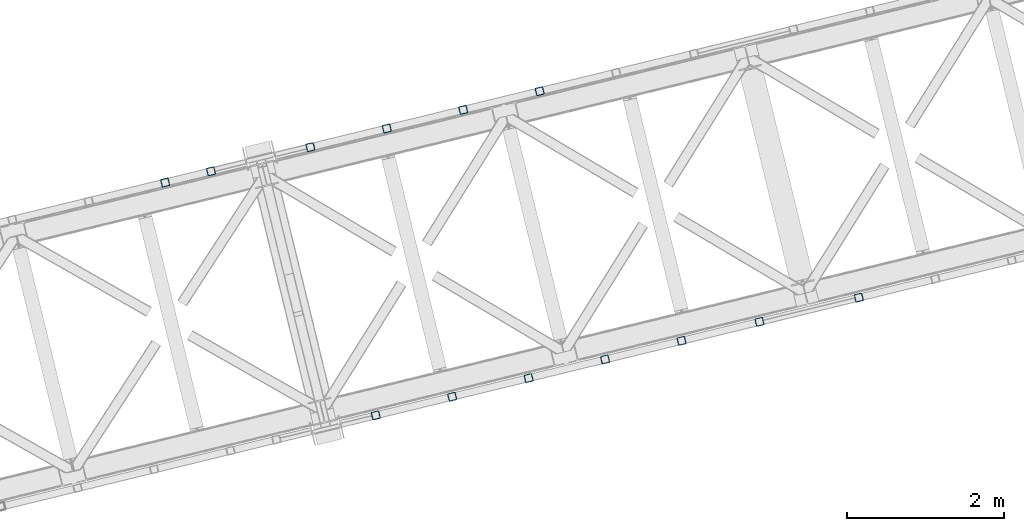
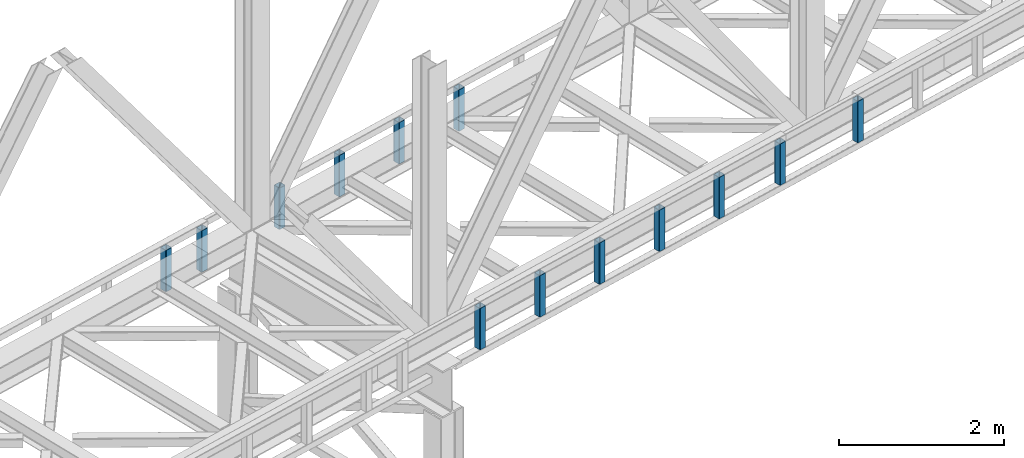
# One storey, part 9 of 92: 13 columns.
"""IFC4 building model written with IfcOpenShell, lengths in millimetres."""

import ifcopenshell
import ifcopenshell.guid

model = None  # the IFC model being written
_history = None  # IfcOwnerHistory: only IFC2X3 demands one
_inside = {}  # id of a spatial element -> (the spatial element, [elements in it])
_under = {}  # id of a project, library or spatial element -> (it, [spatial elements below it])
_declared = {}  # id of a project -> (the project, [libraries it declares])
_typed = {}  # id of a type object -> (the type object, [elements of that type])
_made_of = {}  # id of a material, layer set ... -> (it, [elements and type objects made of it])


def new_model(schema):
    """Start an empty IFC model of exactly this schema.

    Asked for "IFC4X3", IfcOpenShell would pick the latest addendum, in which some entities
    have other attributes; the version numbers below select the first issue.
    IFC2X3 requires an IfcOwnerHistory on every rooted entity: one is made here for all.
    """
    global model, _history
    if schema == "IFC4X3":
        model = ifcopenshell.file(schema_version=(4, 3, 0, 0))
    else:
        model = ifcopenshell.file(schema=schema)
    _inside.clear()
    _under.clear()
    _declared.clear()
    _typed.clear()
    _made_of.clear()
    _history = None
    if model.schema == "IFC2X3":
        org = make("IfcOrganization", Name="unknown")
        user = make(
            "IfcPersonAndOrganization",
            ThePerson=make("IfcPerson", FamilyName="unknown"),
            TheOrganization=org,
        )
        app = make(
            "IfcApplication",
            ApplicationDeveloper=org,
            Version="unknown",
            ApplicationFullName="unknown",
            ApplicationIdentifier="unknown",
        )
        _history = make(
            "IfcOwnerHistory",
            OwningUser=user,
            OwningApplication=app,
            ChangeAction="ADDED",
            CreationDate=0,
        )
    return model


def make(cls, **values):
    """One entity of the class cls with the attributes given. An attribute that is None is left unset."""
    return model.create_entity(
        cls, **{name: value for name, value in values.items() if value is not None}
    )


def entity(cls, *values):
    """Any entity or typed value of the class cls, its attributes in the order of the schema. None: left unset."""
    e = model.create_entity(cls)
    for i, value in enumerate(values):
        if value is not None:
            e[i] = value
    return e


def rooted(cls, **values):
    """An entity with a GlobalId (a new one), such as an element, a storey or a relation."""
    return make(cls, GlobalId=ifcopenshell.guid.new(), OwnerHistory=_history, **values)


def si_unit(unit_type, name, prefix=None):
    """IfcSIUnit, for example si_unit("LENGTHUNIT", "METRE", prefix="MILLI")."""
    return make("IfcSIUnit", UnitType=unit_type, Prefix=prefix, Name=name)


def converted_unit(unit_type, name, factor, base, dimensions=None, offset=None):
    """IfcConversionBasedUnit, such as the inch: factor (a typed value) times the base unit."""
    return make(
        "IfcConversionBasedUnit"
        if offset is None
        else "IfcConversionBasedUnitWithOffset",
        ConversionOffset=offset,
        Dimensions=None
        if dimensions is None
        else entity("IfcDimensionalExponents", *dimensions),
        UnitType=unit_type,
        Name=name,
        ConversionFactor=make(
            "IfcMeasureWithUnit", ValueComponent=factor, UnitComponent=base
        ),
    )


def derived_unit(unit_type, elements):
    """IfcDerivedUnit: a product of units, each with its exponent."""
    return make(
        "IfcDerivedUnit",
        Elements=[
            make("IfcDerivedUnitElement", Unit=unit, Exponent=power)
            for unit, power in elements
        ],
        UnitType=unit_type,
    )


def assignment(units):
    """IfcUnitAssignment: the units of a project."""
    return None if units is None else make("IfcUnitAssignment", Units=units)


def point(xyz):
    """IfcCartesianPoint."""
    return None if xyz is None else make("IfcCartesianPoint", Coordinates=xyz)


def direction(xyz):
    """IfcDirection."""
    return None if xyz is None else make("IfcDirection", DirectionRatios=xyz)


def frame(location, z_axis=None, x_axis=None):
    """IfcAxis2Placement3D, a coordinate frame: its origin and axes. An axis left out is left unset."""
    return make(
        "IfcAxis2Placement3D",
        Location=point(location),
        Axis=direction(z_axis),
        RefDirection=direction(x_axis),
    )


def origin():
    """The frame at (0, 0, 0) with its axes left unset."""
    return frame((0.0, 0.0, 0.0))


def place(relative_to, where):
    """IfcLocalPlacement: puts the frame where relative to a parent placement (None: the world)."""
    return make(
        "IfcLocalPlacement", PlacementRelTo=relative_to, RelativePlacement=where
    )


def context(
    kind, dimensions, precision=None, world=None, true_north=None, identifier=None
):
    """IfcGeometricRepresentationContext, for example the 3D "Model" context."""
    return make(
        "IfcGeometricRepresentationContext",
        ContextIdentifier=identifier,
        ContextType=kind,
        CoordinateSpaceDimension=dimensions,
        Precision=precision,
        WorldCoordinateSystem=world,
        TrueNorth=true_north,
    )


def subcontext(parent, identifier, kind, view, scale=None):
    """IfcGeometricRepresentationSubContext, for example "Body" below "Model"."""
    return make(
        "IfcGeometricRepresentationSubContext",
        ContextIdentifier=identifier,
        ContextType=kind,
        ParentContext=parent,
        TargetScale=scale,
        TargetView=view,
    )


def project(units=None, contexts=None):
    """IfcProject with its units and contexts."""
    return rooted(
        "IfcProject",
        Name="project",
        RepresentationContexts=contexts,
        UnitsInContext=assignment(units),
    )


def spatial(cls, under=None, at=None, **own):
    """A site, building, storey or space (cls), placed at a placement, below another one or the project."""
    s = rooted(cls, ObjectPlacement=at, **own)
    if under is not None:
        _under.setdefault(under.id(), (under, []))[1].append(s)
    return s


def point_list(points):
    """IfcCartesianPointList2D or 3D."""
    cls = (
        "IfcCartesianPointList2D" if len(points[0]) == 2 else "IfcCartesianPointList3D"
    )
    return make(cls, CoordList=points)


def indexed_curve(points, segments=None, self_intersect=None):
    """IfcIndexedPolyCurve: lines and arcs through numbered points (the first is 1)."""
    return make(
        "IfcIndexedPolyCurve",
        Points=point_list(points),
        Segments=segments,
        SelfIntersect=self_intersect,
    )


def outline(outer, holes=None, kind="AREA"):
    """IfcArbitraryClosedProfileDef: a profile drawn as a closed curve; with holes, ...WithVoids."""
    if holes is None:
        return make("IfcArbitraryClosedProfileDef", ProfileType=kind, OuterCurve=outer)
    return make(
        "IfcArbitraryProfileDefWithVoids",
        ProfileType=kind,
        OuterCurve=outer,
        InnerCurves=holes,
    )


def extrude(swept, where, along, depth):
    """IfcExtrudedAreaSolid: the profile swept, set in the frame where, extruded along a direction by depth."""
    return make(
        "IfcExtrudedAreaSolid",
        SweptArea=swept,
        Position=where,
        ExtrudedDirection=direction(along),
        Depth=depth,
    )


def shape(context_of_items, identifier, shape_type, items):
    """IfcShapeRepresentation: the items that make up one representation, for example the "Body"."""
    return make(
        "IfcShapeRepresentation",
        ContextOfItems=context_of_items,
        RepresentationIdentifier=identifier,
        RepresentationType=shape_type,
        Items=items,
    )


def made_of(thing, what):
    """Note that an element or type object is made of a material, layer set ...; save() writes the relation."""
    if what is not None:
        _made_of.setdefault(what.id(), (what, []))[1].append(thing)
    return thing


def type_object(cls, material=None, **own):
    """A type object (cls), such as IfcWallType, which elements share."""
    return made_of(rooted(cls, **own), material)


def element(
    cls,
    number,
    at=None,
    inside=None,
    cuts=None,
    type_object=None,
    material=None,
    context=None,
    identifier="Body",
    shape_type=None,
    held_by="IfcProductDefinitionShape",
    body=None,
    shapes=None,
    **own,
):
    """One element of the class cls, such as IfcWall. Its Tag is "e" and its number.

    at: its placement. inside: the storey or other place that contains it. cuts: it is an
    opening in that element (IfcRelVoidsElement). A single representation is given by context,
    identifier, shape_type and body (its items); several are given by shapes. held_by: the class
    of the entity that holds the representations. save() writes the other relations.
    """
    e = rooted(cls, Tag="e%d" % number, ObjectPlacement=at, **own)
    if body is not None:
        shapes = [shape(context, identifier, shape_type, body)]
    if shapes is not None:
        e.Representation = make(held_by, Representations=shapes)
    if inside is not None:
        _inside.setdefault(inside.id(), (inside, []))[1].append(e)
    if cuts is not None:
        rooted(
            "IfcRelVoidsElement", RelatingBuildingElement=cuts, RelatedOpeningElement=e
        )
    if type_object is not None:
        _typed.setdefault(type_object.id(), (type_object, []))[1].append(e)
    return made_of(e, material)


def aggregate(whole, parts):
    """IfcRelAggregates: a whole, such as a stair, and the parts it consists of."""
    return rooted("IfcRelAggregates", RelatingObject=whole, RelatedObjects=parts)


def save(model, path):
    """Write the relations noted so far, then the file.

    IfcRelAggregates (storeys below a building ...), IfcRelContainedInSpatialStructure (elements
    in a storey), IfcRelDefinesByType, IfcRelAssociatesMaterial and IfcRelDeclares: one each for
    every whole, place, type object, material and project.
    """
    for whole, parts in _under.values():
        aggregate(whole, parts)
    for where, things in _inside.values():
        rooted(
            "IfcRelContainedInSpatialStructure",
            RelatedElements=things,
            RelatingStructure=where,
        )
    for kind, things in _typed.values():
        rooted("IfcRelDefinesByType", RelatedObjects=things, RelatingType=kind)
    for what, things in _made_of.values():
        rooted("IfcRelAssociatesMaterial", RelatedObjects=things, RelatingMaterial=what)
    for by, libraries in _declared.values():
        rooted("IfcRelDeclares", RelatingContext=by, RelatedDefinitions=libraries)
    model.write(path)


model = new_model("IFC4")

# Units and contexts
model_context = context("Model", 3, precision=0.01, world=origin(), true_north=direction((6.12303176911189e-17, 1.0)))
plan_context = context("Plan", 3, precision=0.01, world=origin(), true_north=direction((6.12303176911189e-17, 1.0)))
body_context = subcontext(model_context, "Body", "Model", "MODEL_VIEW")
ifc_project = project(units=[si_unit("LENGTHUNIT", "METRE", prefix="MILLI"), si_unit("AREAUNIT", "SQUARE_METRE"), si_unit("VOLUMEUNIT", "CUBIC_METRE"), converted_unit("PLANEANGLEUNIT", "DEGREE", entity("IfcRatioMeasure", 0.0174532925199433), si_unit("PLANEANGLEUNIT", "RADIAN"), dimensions=[0, 0, 0, 0, 0, 0, 0]), si_unit("MASSUNIT", "GRAM", prefix="KILO"), derived_unit("MASSDENSITYUNIT", [(si_unit("MASSUNIT", "GRAM", prefix="KILO"), 1), (si_unit("LENGTHUNIT", "METRE"), -3)]), derived_unit("MOMENTOFINERTIAUNIT", [(si_unit("LENGTHUNIT", "METRE"), 4)]), si_unit("TIMEUNIT", "SECOND"), si_unit("FREQUENCYUNIT", "HERTZ"), si_unit("THERMODYNAMICTEMPERATUREUNIT", "DEGREE_CELSIUS"), derived_unit("THERMALTRANSMITTANCEUNIT", [(si_unit("MASSUNIT", "GRAM", prefix="KILO"), 1), (si_unit("THERMODYNAMICTEMPERATUREUNIT", "KELVIN"), -1), (si_unit("TIMEUNIT", "SECOND"), -3)]), derived_unit("VOLUMETRICFLOWRATEUNIT", [(si_unit("LENGTHUNIT", "METRE"), 3), (si_unit("TIMEUNIT", "SECOND"), -1)]), derived_unit("MASSFLOWRATEUNIT", [(si_unit("MASSUNIT", "GRAM", prefix="KILO"), 1), (si_unit("TIMEUNIT", "SECOND"), -1)]), derived_unit("ROTATIONALFREQUENCYUNIT", [(si_unit("TIMEUNIT", "SECOND"), -1)]), si_unit("ELECTRICCURRENTUNIT", "AMPERE"), si_unit("ELECTRICVOLTAGEUNIT", "VOLT"), si_unit("POWERUNIT", "WATT"), si_unit("FORCEUNIT", "NEWTON", prefix="KILO"), si_unit("ILLUMINANCEUNIT", "LUX"), si_unit("LUMINOUSFLUXUNIT", "LUMEN"), si_unit("LUMINOUSINTENSITYUNIT", "CANDELA"), derived_unit("USERDEFINED", [(si_unit("MASSUNIT", "GRAM", prefix="KILO"), -1), (si_unit("LENGTHUNIT", "METRE"), -2), (si_unit("TIMEUNIT", "SECOND"), 3), (si_unit("LUMINOUSFLUXUNIT", "LUMEN"), 1)]), derived_unit("LINEARVELOCITYUNIT", [(si_unit("LENGTHUNIT", "METRE"), 1), (si_unit("TIMEUNIT", "SECOND"), -1)]), si_unit("PRESSUREUNIT", "PASCAL"), derived_unit("USERDEFINED", [(si_unit("LENGTHUNIT", "METRE"), -2), (si_unit("MASSUNIT", "GRAM", prefix="KILO"), 1), (si_unit("TIMEUNIT", "SECOND"), -2)]), derived_unit("LINEARFORCEUNIT", [(si_unit("MASSUNIT", "GRAM", prefix="KILO"), 1), (si_unit("LENGTHUNIT", "METRE"), 1), (si_unit("TIMEUNIT", "SECOND"), -2), (si_unit("LENGTHUNIT", "METRE"), -1)]), derived_unit("PLANARFORCEUNIT", [(si_unit("MASSUNIT", "GRAM", prefix="KILO"), 1), (si_unit("LENGTHUNIT", "METRE"), 1), (si_unit("TIMEUNIT", "SECOND"), -2), (si_unit("LENGTHUNIT", "METRE"), -2)])], contexts=[model_context, plan_context])

# Site, building, storey
site_placement = place(None, origin())
site = spatial("IfcSite", under=ifc_project, at=site_placement, CompositionType="ELEMENT")
building_placement = place(site_placement, origin())
building = spatial("IfcBuilding", under=site, at=building_placement, CompositionType="ELEMENT")
storey_placement = place(building_placement, frame((0.0, 0.0, 15900.0)))
storey = spatial("IfcBuildingStorey", under=building, at=storey_placement, Name="05", CompositionType="ELEMENT", Elevation=15900.0)

# Columns
column_type_1 = type_object("IfcColumnType", PredefinedType="COLUMN")
placement = place(storey_placement, origin())
element("IfcColumn", 1, at=placement, inside=storey, type_object=column_type_1, ObjectType="Steel Column", PredefinedType="COLUMN", context=body_context, shape_type="SweptSolid", body=[
    extrude(outline(indexed_curve([(29.4768951153068, -56.8428769008217), (33.3787015556268, -56.8428769008217), (36.9835006656593, -55.3497202198167), (39.7424944584929, -52.5907264269884), (41.2356511394991, -48.9859273169536), (56.8428769008239, 29.4768951152962), (56.8428769008277, 33.3787015556192), (55.3497202198177, 36.9835006656564), (52.5907264269925, 39.7424944584862), (48.9859273169625, 41.2356511394926), (-29.4768951152941, 56.8428769008181), (-33.378701555618, 56.84287690082), (-36.9835006656514, 55.349720219813), (-39.7424944584841, 52.5907264269868), (-41.2356511394904, 48.9859273169519), (-56.8428769008112, -29.4768951152997), (-56.8428769008189, -33.3787015556209), (-55.3497202198089, -36.9835006656581), (-52.5907264269837, -39.7424944584879), (-48.9859273169498, -41.2356511394961), (29.4768951153068, -56.8428769008217)], self_intersect=False), holes=[indexed_curve([(-43.1065493048469, -37.3071763475629), (-46.7113484148769, -35.8140196665565), (-49.470342207706, -33.0550258737249), (-50.9634988887121, -29.4502267636895), (-50.9634988887131, -25.5484203233666), (-37.3071763475533, 43.106549304852), (-35.8140196665471, 46.7113484148868), (-33.0550258737135, 49.470342207715), (-29.4502267636761, 50.9634988887202), (-25.5484203233571, 50.9634988887182), (43.1065493048605, 37.3071763475613), (46.7113484148953, 35.8140196665551), (49.4703422077302, 33.0550258737255), (50.9634988887296, 29.4502267636861), (50.9634988887306, 25.5484203233633), (37.3071763475739, -43.1065493048592), (35.8140196665637, -46.7113484148922), (33.0550258737331, -49.4703422077242), (29.4502267636888, -50.9634988887237), (25.5484203233707, -50.9634988887198), (-43.1065493048469, -37.3071763475629)], self_intersect=False)]), frame((-26664.23, 14498.52, 3168.0), z_axis=(0.0, 0.0, 1.0), x_axis=(0.906681479027134, 0.421815949898968, 0.0)), (0.0, 0.0, 1.0), 612.000000000008),
])
column_type_2 = type_object("IfcColumnType", PredefinedType="COLUMN")
element("IfcColumn", 2, at=placement, inside=storey, type_object=column_type_2, ObjectType="Steel Column", PredefinedType="COLUMN", context=body_context, shape_type="SweptSolid", body=[
    extrude(outline(indexed_curve([(29.4768951153139, -56.8428769008055), (33.3787015556426, -56.8428769008055), (36.9835006656793, -55.3497202197988), (39.7424944585069, -52.5907264269696), (41.2356511395155, -48.9859273169359), (56.8428769008033, 29.4768951153245), (56.8428769008045, 33.3787015556455), (55.3497202197968, 36.9835006656802), (52.5907264269665, 39.7424944585106), (48.9859273169271, 41.2356511395171), (-29.4768951153315, 56.8428769008089), (-33.3787015556514, 56.8428769008072), (-36.9835006656881, 55.3497202198005), (-39.7424944585108, 52.5907264269714), (-41.2356511395243, 48.9859273169376), (-56.842876900812, -29.4768951153228), (-56.8428769008093, -33.3787015556456), (-55.3497202198065, -36.9835006656805), (-52.5907264269753, -39.742494458509), (-48.9859273169447, -41.2356511395138), (29.4768951153139, -56.8428769008055)], self_intersect=False), holes=[indexed_curve([(-43.1065493048483, -37.3071763475781), (-46.711348414878, -35.8140196665713), (-49.4703422077083, -33.0550258737409), (-50.9634988887129, -29.45022676371), (-50.9634988887147, -25.5484203233852), (-37.3071763475856, 43.1065493048374), (-35.8140196665791, 46.7113484148768), (-33.0550258737515, 49.4703422077061), (-29.4502267637158, 50.9634988887108), (-25.5484203233958, 50.9634988887125), (43.1065493048316, 37.3071763475835), (46.7113484148662, 35.8140196665768), (49.4703422076956, 33.0550258737444), (50.963498888709, 29.4502267637118), (50.9634988887069, 25.5484203233888), (37.3071763475768, -43.1065493048357), (35.8140196665743, -46.7113484148769), (33.0550258737379, -49.4703422077045), (29.4502267636982, -50.9634988887074), (25.5484203233792, -50.9634988887072), (-43.1065493048483, -37.3071763475781)], self_intersect=False)]), frame((-27635.78, 14261.69, 3168.0), z_axis=(0.0, 0.0, 1.0), x_axis=(0.906681479027317, 0.421815949898576, 0.0)), (0.0, 0.0, 1.0), 612.000000000008),
])
column_type_3 = type_object("IfcColumnType", PredefinedType="COLUMN")
element("IfcColumn", 3, at=placement, inside=storey, type_object=column_type_3, ObjectType="Steel Column", PredefinedType="COLUMN", context=body_context, shape_type="SweptSolid", body=[
    extrude(outline(indexed_curve([(29.4768951152902, -56.8428769008163), (33.3787015556102, -56.8428769008163), (36.9835006656514, -55.349720219813), (39.7424944584802, -52.5907264269849), (41.2356511394952, -48.9859273169518), (56.8428769008161, 29.4768951152999), (56.842876900815, 33.3787015556227), (55.3497202198089, 36.9835006656581), (52.5907264269798, 39.7424944584897), (48.9859273169459, 41.2356511394979), (-29.4768951153068, 56.8428769008217), (-33.3787015556268, 56.8428769008217), (-36.9835006656593, 55.3497202198166), (-39.742494458488, 52.5907264269886), (-41.235651139503, 48.9859273169554), (-56.8428769008239, -29.4768951152962), (-56.8428769008229, -33.3787015556191), (-55.3497202198177, -36.9835006656564), (-52.5907264269964, -39.7424944584844), (-48.9859273169625, -41.2356511394926), (29.4768951152902, -56.8428769008163)], self_intersect=False), holes=[indexed_curve([(-43.1065493048635, -37.3071763475575), (-46.7113484148896, -35.814019666553), (-49.4703422077169, -33.0550258737174), (-50.9634988887248, -29.450226763686), (-50.963498888721, -25.548420323363), (-37.307176347566, 43.1065493048555), (-35.814019666554, 46.7113484148924), (-33.055025873731, 49.4703422077184), (-29.4502267636928, 50.9634988887255), (-25.5484203233728, 50.9634988887255), (43.1065493048487, 37.3071763475668), (46.7113484148835, 35.8140196665606), (49.4703422077166, 33.0550258737271), (50.9634988887169, 29.4502267636896), (50.9634988887228, 25.5484203233669), (37.3071763475621, -43.1065493048537), (35.8140196665528, -46.7113484148847), (33.0550258737201, -49.470342207711), (29.450226763677, -50.9634988887182), (25.548420323358, -50.9634988887163), (-43.1065493048635, -37.3071763475575)], self_intersect=False)]), frame((-28607.33, 14024.86, 3168.0), z_axis=(0.0, 0.0, 1.0), x_axis=(0.906681479027134, 0.421815949898968, 0.0)), (0.0, 0.0, 1.0), 612.000000000008),
])
column_type_4 = type_object("IfcColumnType", PredefinedType="COLUMN")
element("IfcColumn", 4, at=placement, inside=storey, type_object=column_type_4, ObjectType="Steel Column", PredefinedType="COLUMN", context=body_context, shape_type="SweptSolid", body=[
    extrude(outline(indexed_curve([(29.476895115295, -56.8428769008162), (33.378701555615, -56.8428769008162), (36.9835006656514, -55.349720219813), (39.7424944584899, -52.5907264269846), (41.2356511394922, -48.985927316948), (56.842876900817, 29.4768951153019), (56.8428769008247, 33.378701555623), (55.3497202198098, 36.9835006656601), (52.5907264269807, 39.7424944584917), (48.9859273169507, 41.2356511394981), (-29.4768951152972, 56.8428769008219), (-33.378701555621, 56.8428769008238), (-36.9835006656544, 55.3497202198168), (-39.7424944584832, 52.5907264269887), (-41.2356511394934, 48.9859273169557), (-56.8428769008142, -29.476895115296), (-56.842876900818, -33.3787015556189), (-55.349720219812, -36.9835006656543), (-52.5907264269868, -39.7424944584841), (-48.9859273169529, -41.2356511394923), (29.476895115295, -56.8428769008162)], self_intersect=False), holes=[indexed_curve([(-43.1065493048596, -37.3071763475593), (-46.7113484148877, -35.814019666549), (-49.4703422077187, -33.0550258737213), (-50.9634988887199, -29.4502267636858), (-50.963498888721, -25.548420323363), (-37.3071763475572, 43.1065493048538), (-35.8140196665549, 46.7113484148905), (-33.0550258737253, 49.4703422077205), (-29.4502267636888, 50.9634988887237), (-25.5484203233689, 50.9634988887237), (43.1065493048575, 37.3071763475651), (46.7113484148865, 35.8140196665568), (49.4703422077175, 33.0550258737291), (50.9634988887178, 29.4502267636916), (50.9634988887237, 25.5484203233689), (37.307176347566, -43.1065493048555), (35.8140196665528, -46.7113484148847), (33.0550258737204, -49.4703422077206), (29.4502267636858, -50.9634988887199), (25.5484203233668, -50.9634988887179), (-43.1065493048596, -37.3071763475593)], self_intersect=False)]), frame((-29578.88, 13788.04, 3168.0), z_axis=(0.0, 0.0, 1.0), x_axis=(0.906681479027134, 0.421815949898968, 0.0)), (0.0, 0.0, 1.0), 612.000000000008),
])
column_type_5 = type_object("IfcColumnType", PredefinedType="COLUMN")
element("IfcColumn", 5, at=placement, inside=storey, type_object=column_type_5, ObjectType="Steel Column", PredefinedType="COLUMN", context=body_context, shape_type="SweptSolid", body=[
    extrude(outline(indexed_curve([(29.476895115299, -56.842876900818), (33.3787015556189, -56.842876900818), (36.9835006656514, -55.349720219813), (39.7424944584899, -52.5907264269847), (41.2356511394952, -48.9859273169518), (56.842876900817, 29.4768951153019), (56.8428769008247, 33.378701555623), (55.3497202198098, 36.9835006656601), (52.5907264269886, 39.742494458488), (48.9859273169547, 41.2356511394962), (-29.476895115302, 56.8428769008218), (-33.378701555621, 56.8428769008238), (-36.9835006656544, 55.3497202198168), (-39.7424944584832, 52.5907264269887), (-41.2356511394982, 48.9859273169556), (-56.8428769008191, -29.4768951152961), (-56.842876900818, -33.3787015556189), (-55.3497202198129, -36.9835006656563), (-52.5907264269877, -39.7424944584861), (-48.9859273169577, -41.2356511394924), (29.476895115299, -56.842876900818)], self_intersect=False), holes=[indexed_curve([(-43.1065493048557, -37.3071763475612), (-46.7113484148856, -35.8140196665548), (-49.4703422077196, -33.0550258737233), (-50.9634988887208, -29.4502267636878), (-50.9634988887219, -25.548420323365), (-37.3071763475651, 43.1065493048575), (-35.814019666554, 46.7113484148924), (-33.0550258737213, 49.4703422077187), (-29.450226763684, 50.9634988887238), (-25.548420323365, 50.9634988887219), (43.1065493048526, 37.307176347565), (46.7113484148826, 35.8140196665586), (49.4703422077175, 33.0550258737291), (50.9634988887257, 29.4502267636879), (50.9634988887228, 25.5484203233669), (37.3071763475699, -43.1065493048573), (35.814019666551, -46.7113484148886), (33.0550258737204, -49.4703422077206), (29.450226763681, -50.96349888872), (25.5484203233619, -50.9634988887181), (-43.1065493048557, -37.3071763475612)], self_intersect=False)]), frame((-30841.9, 13480.16, 3168.0), z_axis=(0.0, 0.0, 1.0), x_axis=(0.906681479027134, 0.421815949898968, 0.0)), (0.0, 0.0, 1.0), 612.000000000008),
])
column_type_6 = type_object("IfcColumnType", PredefinedType="COLUMN")
element("IfcColumn", 6, at=placement, inside=storey, type_object=column_type_6, ObjectType="Steel Column", PredefinedType="COLUMN", context=body_context, shape_type="SweptSolid", body=[
    extrude(outline(indexed_curve([(29.4768951152941, -56.8428769008181), (33.3787015556141, -56.8428769008181), (36.9835006656466, -55.3497202198131), (39.742494458485, -52.5907264269848), (41.2356511394904, -48.9859273169519), (56.8428769008121, 29.4768951153017), (56.8428769008198, 33.3787015556228), (55.349720219805, 36.9835006656599), (52.5907264269837, 39.7424944584879), (48.9859273169498, 41.2356511394961), (-29.4768951153068, 56.8428769008217), (-33.3787015556259, 56.8428769008236), (-36.9835006656593, 55.3497202198167), (-39.742494458488, 52.5907264269886), (-41.235651139503, 48.9859273169554), (-56.8428769008239, -29.4768951152962), (-56.8428769008229, -33.3787015556191), (-55.3497202198177, -36.9835006656564), (-52.5907264269925, -39.7424944584862), (-48.9859273169625, -41.2356511394926), (29.4768951152941, -56.8428769008181)], self_intersect=False), holes=[indexed_curve([(-43.1065493048605, -37.3071763475613), (-46.7113484148886, -35.814019666551), (-49.4703422077196, -33.0550258737233), (-50.9634988887208, -29.4502267636878), (-50.9634988887219, -25.548420323365), (-37.307176347566, 43.1065493048555), (-35.814019666554, 46.7113484148924), (-33.0550258737262, 49.4703422077185), (-29.4502267636888, 50.9634988887237), (-25.5484203233698, 50.9634988887217), (43.1065493048478, 37.3071763475648), (46.7113484148826, 35.8140196665586), (49.4703422077166, 33.0550258737271), (50.9634988887208, 29.4502267636878), (50.9634988887228, 25.5484203233669), (37.3071763475651, -43.1065493048575), (35.814019666551, -46.7113484148886), (33.0550258737195, -49.4703422077226), (29.4502267636761, -50.9634988887202), (25.5484203233571, -50.9634988887182), (-43.1065493048605, -37.3071763475613)], self_intersect=False)]), frame((-31424.83, 13338.07, 3168.0), z_axis=(0.0, 0.0, 1.0), x_axis=(0.906681479027134, 0.421815949898968, 0.0)), (0.0, 0.0, 1.0), 612.000000000008),
])
column_type_7 = type_object("IfcColumnType", PredefinedType="COLUMN")
element("IfcColumn", 7, at=placement, inside=storey, type_object=column_type_7, ObjectType="Steel Column", PredefinedType="COLUMN", context=body_context, shape_type="SweptSolid", body=[
    extrude(outline(indexed_curve([(29.476895115299, -56.842876900818), (33.3787015556189, -56.842876900818), (36.9835006656554, -55.3497202198148), (39.742494458489, -52.5907264269866), (41.2356511394952, -48.9859273169518), (56.8428769008161, 29.4768951152999), (56.8428769008238, 33.378701555621), (55.3497202198138, 36.9835006656582), (52.5907264269847, 39.7424944584899), (48.9859273169547, 41.2356511394962), (-29.4768951152981, 56.84287690082), (-33.3787015556219, 56.8428769008218), (-36.9835006656544, 55.3497202198168), (-39.742494458488, 52.5907264269886), (-41.2356511394982, 48.9859273169556), (-56.84287690082, -29.4768951152981), (-56.8428769008229, -33.3787015556191), (-55.3497202198129, -36.9835006656563), (-52.5907264269916, -39.7424944584843), (-48.9859273169538, -41.2356511394943), (29.476895115299, -56.842876900818)], self_intersect=False), holes=[indexed_curve([(-43.1065493048557, -37.3071763475612), (-46.7113484148886, -35.814019666551), (-49.4703422077138, -33.0550258737212), (-50.9634988887248, -29.450226763686), (-50.9634988887258, -25.5484203233631), (-37.307176347569, 43.1065493048593), (-35.8140196665589, 46.7113484148923), (-33.0550258737213, 49.4703422077187), (-29.4502267636879, 50.9634988887257), (-25.548420323365, 50.9634988887219), (43.1065493048536, 37.3071763475669), (46.7113484148875, 35.8140196665587), (49.4703422077166, 33.0550258737271), (50.9634988887169, 29.4502267636896), (50.9634988887189, 25.5484203233687), (37.3071763475581, -43.1065493048519), (35.8140196665528, -46.7113484148847), (33.0550258737201, -49.470342207711), (29.4502267636858, -50.9634988887199), (25.5484203233668, -50.9634988887179), (-43.1065493048557, -37.3071763475612)], self_intersect=False)]), frame((-22607.65, 11875.6, 3168.0), z_axis=(0.0, 0.0, 1.0), x_axis=(-0.906681479027134, -0.421815949898968, 0.0)), (0.0, 0.0, 1.0), 612.000000000008),
])
column_type_8 = type_object("IfcColumnType", PredefinedType="COLUMN")
element("IfcColumn", 8, at=placement, inside=storey, type_object=column_type_8, ObjectType="Steel Column", PredefinedType="COLUMN", context=body_context, shape_type="SweptSolid", body=[
    extrude(outline(indexed_curve([(29.476895115302, -56.8428769008218), (33.3787015556219, -56.8428769008218), (36.9835006656593, -55.3497202198167), (39.7424944584929, -52.5907264269884), (41.2356511394982, -48.9859273169556), (56.84287690082, 29.4768951152981), (56.8428769008277, 33.3787015556192), (55.3497202198177, 36.9835006656564), (52.5907264269877, 39.7424944584861), (48.9859273169577, 41.2356511394924), (-29.4768951152941, 56.8428769008181), (-33.3787015556141, 56.8428769008181), (-36.9835006656514, 55.349720219813), (-39.742494458485, 52.5907264269848), (-41.2356511394904, 48.9859273169519), (-56.8428769008121, -29.4768951153017), (-56.8428769008198, -33.3787015556228), (-55.3497202198098, -36.9835006656601), (-52.5907264269837, -39.7424944584879), (-48.9859273169498, -41.2356511394961), (29.476895115302, -56.8428769008218)], self_intersect=False), holes=[indexed_curve([(-43.1065493048526, -37.307176347565), (-46.7113484148886, -35.814019666551), (-49.4703422077175, -33.0550258737291), (-50.9634988887217, -29.4502267636897), (-50.9634988887219, -25.548420323365), (-37.3071763475572, 43.1065493048538), (-35.8140196665549, 46.7113484148905), (-33.0550258737204, 49.4703422077206), (-29.4502267636849, 50.9634988887219), (-25.5484203233619, 50.9634988887181), (43.1065493048566, 37.3071763475631), (46.7113484148905, 35.8140196665549), (49.4703422077187, 33.0550258737213), (50.9634988887208, 29.4502267636878), (50.9634988887219, 25.548420323365), (37.3071763475621, -43.1065493048537), (35.8140196665558, -46.7113484148885), (33.0550258737223, -49.4703422077167), (29.4502267636888, -50.9634988887237), (25.5484203233698, -50.9634988887217), (-43.1065493048526, -37.307176347565)], self_intersect=False)]), frame((-23870.67, 11567.73, 3168.0), z_axis=(0.0, 0.0, 1.0), x_axis=(-0.906681479027134, -0.421815949898968, 0.0)), (0.0, 0.0, 1.0), 612.000000000008),
])
column_type_9 = type_object("IfcColumnType", PredefinedType="COLUMN")
element("IfcColumn", 9, at=placement, inside=storey, type_object=column_type_9, ObjectType="Steel Column", PredefinedType="COLUMN", context=body_context, shape_type="SweptSolid", body=[
    extrude(outline(indexed_curve([(29.4768951153038, -56.8428769008179), (33.3787015556238, -56.8428769008179), (36.9835006656602, -55.3497202198147), (39.742494458485, -52.5907264269848), (41.2356511395, -48.9859273169517), (56.8428769008209, 29.4768951153), (56.8428769008198, 33.3787015556229), (55.3497202198186, 36.9835006656584), (52.5907264269895, 39.74249445849), (48.9859273169595, 41.2356511394964), (-29.4768951152932, 56.8428769008201), (-33.378701555621, 56.8428769008238), (-36.9835006656584, 55.3497202198186), (-39.742494458488, 52.5907264269886), (-41.2356511394982, 48.9859273169556), (-56.8428769008191, -29.4768951152961), (-56.8428769008229, -33.3787015556191), (-55.3497202198168, -36.9835006656544), (-52.5907264269877, -39.7424944584861), (-48.9859273169489, -41.2356511394941), (29.4768951153038, -56.8428769008179)], self_intersect=False), holes=[indexed_curve([(-43.1065493048508, -37.307176347561), (-46.7113484148847, -35.8140196665528), (-49.4703422077138, -33.0550258737212), (-50.9634988887248, -29.450226763686), (-50.963498888721, -25.548420323363), (-37.3071763475612, 43.1065493048557), (-35.8140196665561, 46.7113484148982), (-33.0550258737204, 49.4703422077206), (-29.4502267636831, 50.9634988887258), (-25.5484203233601, 50.963498888722), (43.1065493048575, 37.3071763475651), (46.7113484148935, 35.8140196665511), (49.4703422077205, 33.0550258737253), (50.9634988887226, 29.4502267636917), (50.9634988887237, 25.5484203233689), (37.307176347563, -43.1065493048517), (35.8140196665558, -46.7113484148885), (33.0550258737232, -49.4703422077148), (29.4502267636907, -50.9634988887198), (25.5484203233707, -50.9634988887198), (-43.1065493048508, -37.307176347561)], self_intersect=False)]), frame((-24861.65, 11326.17, 3168.0), z_axis=(0.0, 0.0, 1.0), x_axis=(-0.906681479027134, -0.421815949898968, 0.0)), (0.0, 0.0, 1.0), 612.000000000008),
])
column_type_10 = type_object("IfcColumnType", PredefinedType="COLUMN")
element("IfcColumn", 10, at=placement, inside=storey, type_object=column_type_10, ObjectType="Steel Column", PredefinedType="COLUMN", context=body_context, shape_type="SweptSolid", body=[
    extrude(outline(indexed_curve([(29.476895115302, -56.8428769008218), (33.3787015556219, -56.8428769008218), (36.9835006656584, -55.3497202198186), (39.742494458492, -52.5907264269904), (41.2356511394982, -48.9859273169556), (56.8428769008191, 29.4768951152961), (56.8428769008268, 33.3787015556172), (55.3497202198168, 36.9835006656544), (52.5907264269877, 39.7424944584861), (48.9859273169577, 41.2356511394924), (-29.476895115299, 56.842876900818), (-33.3787015556189, 56.842876900818), (-36.9835006656514, 55.349720219813), (-39.742494458485, 52.5907264269848), (-41.2356511394952, 48.9859273169518), (-56.842876900817, -29.4768951153019), (-56.8428769008198, -33.3787015556229), (-55.3497202198098, -36.9835006656601), (-52.5907264269886, -39.742494458488), (-48.9859273169547, -41.2356511394962), (29.476895115302, -56.8428769008218)], self_intersect=False), holes=[indexed_curve([(-43.1065493048526, -37.307176347565), (-46.7113484148914, -35.8140196665569), (-49.4703422077223, -33.0550258737292), (-50.9634988887226, -29.4502267636917), (-50.9634988887228, -25.5484203233669), (-37.307176347566, 43.1065493048555), (-35.8140196665558, 46.7113484148885), (-33.0550258737253, 49.4703422077205), (-29.4502267636849, 50.9634988887219), (-25.5484203233628, 50.9634988887161), (43.1065493048517, 37.307176347563), (46.7113484148838, 35.8140196665509), (49.4703422077138, 33.0550258737212), (50.9634988887199, 29.4502267636858), (50.963498888721, 25.548420323363), (37.3071763475612, -43.1065493048557), (35.8140196665549, -46.7113484148905), (33.0550258737174, -49.4703422077169), (29.450226763684, -50.9634988887238), (25.548420323365, -50.9634988887219), (-43.1065493048526, -37.307176347565)], self_intersect=False)]), frame((-25833.2, 11089.34, 3168.0), z_axis=(0.0, 0.0, 1.0), x_axis=(-0.906681479027134, -0.421815949898968, 0.0)), (0.0, 0.0, 1.0), 612.000000000008),
])
column_type_11 = type_object("IfcColumnType", PredefinedType="COLUMN")
element("IfcColumn", 11, at=placement, inside=storey, type_object=column_type_11, ObjectType="Steel Column", PredefinedType="COLUMN", context=body_context, shape_type="SweptSolid", body=[
    extrude(outline(indexed_curve([(29.4768951153315, -56.842876900805), (33.3787015556506, -56.842876900805), (36.9835006656871, -55.349720219798), (39.7424944585106, -52.5907264269667), (41.2356511395238, -48.9859273169329), (56.8428769008051, 29.4768951153267), (56.8428769008021, 33.3787015556495), (55.3497202197991, 36.9835006656843), (52.5907264269686, 39.7424944585145), (48.9859273169378, 41.2356511395191), (-29.4768951153227, 56.8428769008033), (-33.3787015556515, 56.842876900803), (-36.9835006656871, 55.349720219798), (-39.7424944585154, 52.5907264269666), (-41.2356511395238, 48.9859273169329), (-56.8428769008051, -29.4768951153267), (-56.842876900807, -33.3787015556496), (-55.3497202197991, -36.9835006656843), (-52.5907264269725, -39.7424944585127), (-48.9859273169291, -41.2356511395208), (29.4768951153315, -56.842876900805)], self_intersect=False), holes=[indexed_curve([(-43.1065493048329, -37.3071763475847), (-46.7113484148676, -35.8140196665783), (-49.4703422076981, -33.0550258737481), (-50.9634988887108, -29.4502267637136), (-50.963498888709, -25.5484203233906), (-37.3071763475838, 43.1065493048349), (-35.8140196665805, 46.7113484148782), (-33.0550258737462, 49.470342207702), (-29.4502267637096, 50.963498888709), (-25.5484203233867, 50.9634988887072), (43.1065493048378, 37.3071763475848), (46.7113484148746, 35.8140196665727), (49.470342207702, 33.0550258737462), (50.9634988887069, 29.4502267637154), (50.963498888709, 25.5484203233906), (37.3071763475838, -43.1065493048349), (35.8140196665784, -46.7113484148724), (33.0550258737471, -49.4703422077001), (29.4502267637154, -50.9634988887069), (25.5484203233954, -50.9634988887089), (-43.1065493048329, -37.3071763475847)], self_intersect=False)]), frame((-26804.76, 10852.51, 3168.0), z_axis=(0.0, 0.0, 1.0), x_axis=(-0.906681479027346, -0.421815949898512, 0.0)), (0.0, 0.0, 1.0), 612.000000000008),
])
column_type_12 = type_object("IfcColumnType", PredefinedType="COLUMN")
element("IfcColumn", 12, at=placement, inside=storey, type_object=column_type_12, ObjectType="Steel Column", PredefinedType="COLUMN", context=body_context, shape_type="SweptSolid", body=[
    extrude(outline(indexed_curve([(29.476895115299, -56.842876900818), (33.3787015556189, -56.842876900818), (36.9835006656514, -55.349720219813), (39.7424944584811, -52.590726426983), (41.2356511394952, -48.9859273169518), (56.842876900817, 29.4768951153019), (56.8428769008159, 33.3787015556247), (55.3497202198098, 36.9835006656601), (52.5907264269886, 39.742494458488), (48.9859273169547, 41.2356511394962), (-29.4768951152972, 56.8428769008219), (-33.3787015556171, 56.8428769008219), (-36.9835006656584, 55.3497202198186), (-39.742494458488, 52.5907264269886), (-41.2356511395021, 48.9859273169574), (-56.8428769008239, -29.4768951152962), (-56.8428769008229, -33.3787015556191), (-55.3497202198168, -36.9835006656544), (-52.5907264269868, -39.7424944584841), (-48.9859273169529, -41.2356511394923), (29.476895115299, -56.842876900818)], self_intersect=False), holes=[indexed_curve([(-43.1065493048557, -37.3071763475612), (-46.7113484148905, -35.8140196665549), (-49.4703422077235, -33.0550258737215), (-50.9634988887238, -29.450226763684), (-50.9634988887297, -25.5484203233613), (-37.3071763475699, 43.1065493048573), (-35.8140196665598, 46.7113484148903), (-33.0550258737271, 49.4703422077166), (-29.4502267636879, 50.9634988887257), (-25.548420323365, 50.9634988887219), (43.1065493048526, 37.307176347565), (46.7113484148847, 35.8140196665528), (49.4703422077099, 33.055025873723), (50.9634988887178, 29.4502267636916), (50.963498888714, 25.5484203233686), (37.3071763475581, -43.1065493048519), (35.8140196665471, -46.7113484148868), (33.0550258737201, -49.470342207711), (29.4502267636858, -50.9634988887199), (25.5484203233659, -50.9634988887199), (-43.1065493048557, -37.3071763475612)], self_intersect=False)]), frame((-27776.31, 10615.69, 3168.0), z_axis=(0.0, 0.0, 1.0), x_axis=(-0.906681479027134, -0.421815949898968, 0.0)), (0.0, 0.0, 1.0), 612.000000000008),
])
column_type_13 = type_object("IfcColumnType", PredefinedType="COLUMN")
element("IfcColumn", 13, at=placement, inside=storey, type_object=column_type_13, ObjectType="Steel Column", PredefinedType="COLUMN", context=body_context, shape_type="SweptSolid", body=[
    extrude(outline(indexed_curve([(29.476895115299, -56.842876900818), (33.3787015556189, -56.842876900818), (36.9835006656563, -55.3497202198129), (39.742494458485, -52.5907264269848), (41.2356511394952, -48.9859273169518), (56.842876900817, 29.4768951153019), (56.8428769008198, 33.3787015556228), (55.3497202198147, 36.9835006656602), (52.5907264269886, 39.742494458488), (48.9859273169547, 41.2356511394962), (-29.4768951152932, 56.8428769008201), (-33.3787015556132, 56.8428769008201), (-36.9835006656496, 55.3497202198169), (-39.742494458488, 52.5907264269886), (-41.2356511394934, 48.9859273169557), (-56.8428769008151, -29.4768951152979), (-56.8428769008229, -33.3787015556191), (-55.349720219808, -36.9835006656561), (-52.5907264269828, -39.7424944584859), (-48.9859273169489, -41.2356511394941), (29.476895115299, -56.842876900818)], self_intersect=False), holes=[indexed_curve([(-43.1065493048557, -37.3071763475612), (-46.7113484148886, -35.814019666551), (-49.4703422077166, -33.0550258737271), (-50.963498888716, -29.4502267636876), (-50.9634988887219, -25.548420323365), (-37.3071763475651, 43.1065493048575), (-35.814019666551, 46.7113484148886), (-33.0550258737195, 49.4703422077226), (-29.4502267636879, 50.9634988887257), (-25.548420323365, 50.9634988887219), (43.1065493048575, 37.3071763475651), (46.7113484148926, 35.8140196665492), (49.4703422077205, 33.0550258737253), (50.9634988887217, 29.4502267636897), (50.9634988887228, 25.5484203233669), (37.3071763475591, -43.1065493048499), (35.8140196665568, -46.7113484148865), (33.0550258737232, -49.4703422077148), (29.4502267636907, -50.9634988887198), (25.5484203233707, -50.9634988887198), (-43.1065493048557, -37.3071763475612)], self_intersect=False)]), frame((-28747.86, 10378.86, 3168.0), z_axis=(0.0, 0.0, 1.0), x_axis=(-0.906681479027134, -0.421815949898968, 0.0)), (0.0, 0.0, 1.0), 612.000000000008),
])

save(model, "model.ifc")
